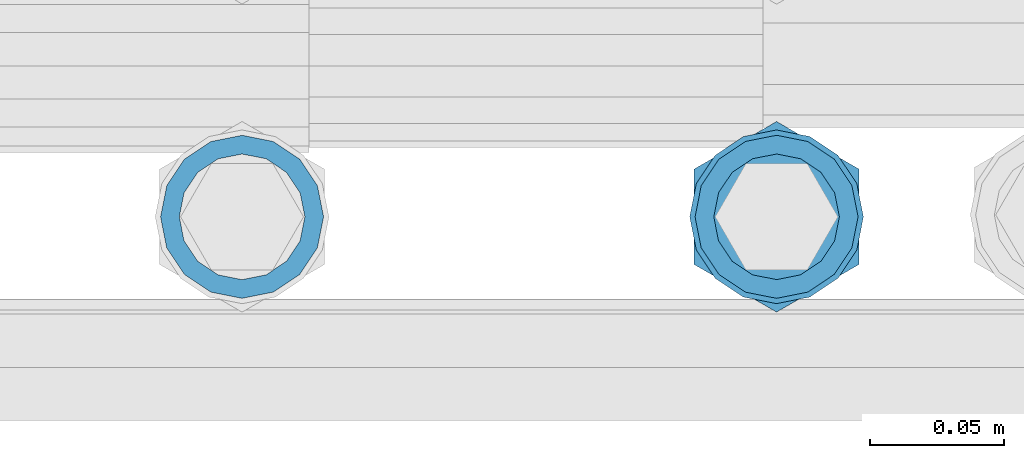
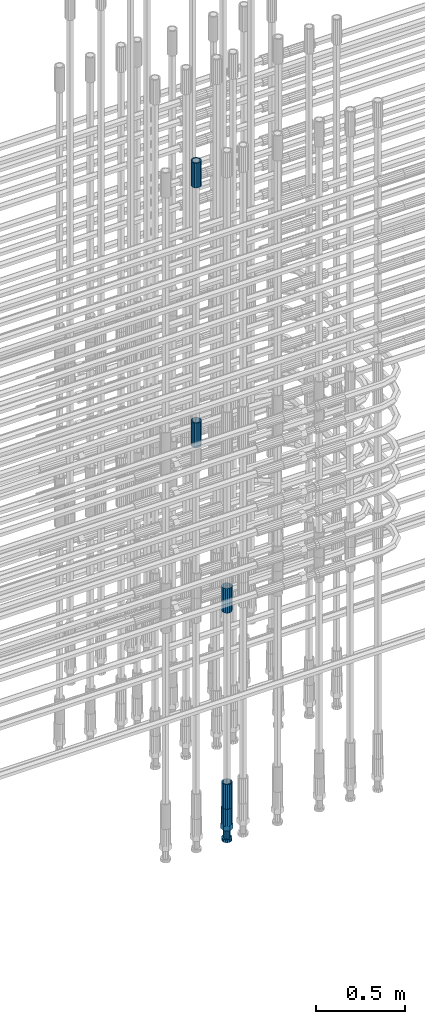
# One storey, part 22 of 119: 5 beams.
"""IFC2X3 building model written with IfcOpenShell, lengths in millimetres."""

import ifcopenshell
import ifcopenshell.guid

model = None  # the IFC model being written
_history = None  # IfcOwnerHistory: only IFC2X3 demands one
_inside = {}  # id of a spatial element -> (the spatial element, [elements in it])
_under = {}  # id of a project, library or spatial element -> (it, [spatial elements below it])
_declared = {}  # id of a project -> (the project, [libraries it declares])
_typed = {}  # id of a type object -> (the type object, [elements of that type])
_made_of = {}  # id of a material, layer set ... -> (it, [elements and type objects made of it])


def new_model(schema):
    """Start an empty IFC model of exactly this schema.

    Asked for "IFC4X3", IfcOpenShell would pick the latest addendum, in which some entities
    have other attributes; the version numbers below select the first issue.
    IFC2X3 requires an IfcOwnerHistory on every rooted entity: one is made here for all.
    """
    global model, _history
    if schema == "IFC4X3":
        model = ifcopenshell.file(schema_version=(4, 3, 0, 0))
    else:
        model = ifcopenshell.file(schema=schema)
    _inside.clear()
    _under.clear()
    _declared.clear()
    _typed.clear()
    _made_of.clear()
    _history = None
    if model.schema == "IFC2X3":
        org = make("IfcOrganization", Name="unknown")
        user = make(
            "IfcPersonAndOrganization",
            ThePerson=make("IfcPerson", FamilyName="unknown"),
            TheOrganization=org,
        )
        app = make(
            "IfcApplication",
            ApplicationDeveloper=org,
            Version="unknown",
            ApplicationFullName="unknown",
            ApplicationIdentifier="unknown",
        )
        _history = make(
            "IfcOwnerHistory",
            OwningUser=user,
            OwningApplication=app,
            ChangeAction="ADDED",
            CreationDate=0,
        )
    return model


def make(cls, **values):
    """One entity of the class cls with the attributes given. An attribute that is None is left unset."""
    return model.create_entity(
        cls, **{name: value for name, value in values.items() if value is not None}
    )


def rooted(cls, **values):
    """An entity with a GlobalId (a new one), such as an element, a storey or a relation."""
    return make(cls, GlobalId=ifcopenshell.guid.new(), OwnerHistory=_history, **values)


def si_unit(unit_type, name, prefix=None):
    """IfcSIUnit, for example si_unit("LENGTHUNIT", "METRE", prefix="MILLI")."""
    return make("IfcSIUnit", UnitType=unit_type, Prefix=prefix, Name=name)


def assignment(units):
    """IfcUnitAssignment: the units of a project."""
    return None if units is None else make("IfcUnitAssignment", Units=units)


def point(xyz):
    """IfcCartesianPoint."""
    return None if xyz is None else make("IfcCartesianPoint", Coordinates=xyz)


def direction(xyz):
    """IfcDirection."""
    return None if xyz is None else make("IfcDirection", DirectionRatios=xyz)


def frame(location, z_axis=None, x_axis=None):
    """IfcAxis2Placement3D, a coordinate frame: its origin and axes. An axis left out is left unset."""
    return make(
        "IfcAxis2Placement3D",
        Location=point(location),
        Axis=direction(z_axis),
        RefDirection=direction(x_axis),
    )


def origin_with_axes():
    """The frame at (0, 0, 0) with the z axis (0, 0, 1) and the x axis (1, 0, 0) written out."""
    return frame((0.0, 0.0, 0.0), z_axis=(0.0, 0.0, 1.0), x_axis=(1.0, 0.0, 0.0))


def place(relative_to, where):
    """IfcLocalPlacement: puts the frame where relative to a parent placement (None: the world)."""
    return make(
        "IfcLocalPlacement", PlacementRelTo=relative_to, RelativePlacement=where
    )


def context(
    kind, dimensions, precision=None, world=None, true_north=None, identifier=None
):
    """IfcGeometricRepresentationContext, for example the 3D "Model" context."""
    return make(
        "IfcGeometricRepresentationContext",
        ContextIdentifier=identifier,
        ContextType=kind,
        CoordinateSpaceDimension=dimensions,
        Precision=precision,
        WorldCoordinateSystem=world,
        TrueNorth=true_north,
    )


def subcontext(parent, identifier, kind, view, scale=None):
    """IfcGeometricRepresentationSubContext, for example "Body" below "Model"."""
    return make(
        "IfcGeometricRepresentationSubContext",
        ContextIdentifier=identifier,
        ContextType=kind,
        ParentContext=parent,
        TargetScale=scale,
        TargetView=view,
    )


def project(units=None, contexts=None):
    """IfcProject with its units and contexts."""
    return rooted(
        "IfcProject",
        Name="project",
        RepresentationContexts=contexts,
        UnitsInContext=assignment(units),
    )


def spatial(cls, under=None, at=None, **own):
    """A site, building, storey or space (cls), placed at a placement, below another one or the project."""
    s = rooted(cls, ObjectPlacement=at, **own)
    if under is not None:
        _under.setdefault(under.id(), (under, []))[1].append(s)
    return s


def faces_of(points, faces, orient=None, outer=None):
    """IfcFace entities. A face is a list of loops; a loop is a list of indices into points, from 0.

    orient and outer hold one flag for each loop. By default every Orientation is true, the
    first loop of a face is its IfcFaceOuterBound and the others are IfcFaceBound.
    """
    made = []
    for i, loops in enumerate(faces):
        bounds = []
        for j, loop in enumerate(loops):
            is_outer = j == 0 if outer is None else outer[i][j]
            bounds.append(
                make(
                    "IfcFaceOuterBound" if is_outer else "IfcFaceBound",
                    Bound=make("IfcPolyLoop", Polygon=[points[k] for k in loop]),
                    Orientation=True if orient is None else orient[i][j],
                )
            )
        made.append(make("IfcFace", Bounds=bounds))
    return made


def faceted_brep(points, faces, orient=None, outer=None, voids=None):
    """IfcFacetedBrep: a solid bounded by flat faces; with voids (closed shells), ...WithVoids."""
    shared = [point(p) for p in points]
    hull = make("IfcClosedShell", CfsFaces=faces_of(shared, faces, orient, outer))
    if voids is None:
        return make("IfcFacetedBrep", Outer=hull)
    return make(
        "IfcFacetedBrepWithVoids",
        Outer=hull,
        Voids=[
            make(cls, CfsFaces=faces_of(shared, fs, o, b)) for cls, fs, o, b in voids
        ],
    )


def shape(context_of_items, identifier, shape_type, items):
    """IfcShapeRepresentation: the items that make up one representation, for example the "Body"."""
    return make(
        "IfcShapeRepresentation",
        ContextOfItems=context_of_items,
        RepresentationIdentifier=identifier,
        RepresentationType=shape_type,
        Items=items,
    )


def material(Name=None, Category=None):
    """IfcMaterial."""
    return make("IfcMaterial", Name=Name, Category=Category)


def made_of(thing, what):
    """Note that an element or type object is made of a material, layer set ...; save() writes the relation."""
    if what is not None:
        _made_of.setdefault(what.id(), (what, []))[1].append(thing)
    return thing


def type_object(cls, material=None, **own):
    """A type object (cls), such as IfcWallType, which elements share."""
    return made_of(rooted(cls, **own), material)


def element(
    cls,
    number,
    at=None,
    inside=None,
    cuts=None,
    type_object=None,
    material=None,
    context=None,
    identifier="Body",
    shape_type=None,
    held_by="IfcProductDefinitionShape",
    body=None,
    shapes=None,
    **own,
):
    """One element of the class cls, such as IfcWall. Its Tag is "e" and its number.

    at: its placement. inside: the storey or other place that contains it. cuts: it is an
    opening in that element (IfcRelVoidsElement). A single representation is given by context,
    identifier, shape_type and body (its items); several are given by shapes. held_by: the class
    of the entity that holds the representations. save() writes the other relations.
    """
    e = rooted(cls, Tag="e%d" % number, ObjectPlacement=at, **own)
    if body is not None:
        shapes = [shape(context, identifier, shape_type, body)]
    if shapes is not None:
        e.Representation = make(held_by, Representations=shapes)
    if inside is not None:
        _inside.setdefault(inside.id(), (inside, []))[1].append(e)
    if cuts is not None:
        rooted(
            "IfcRelVoidsElement", RelatingBuildingElement=cuts, RelatedOpeningElement=e
        )
    if type_object is not None:
        _typed.setdefault(type_object.id(), (type_object, []))[1].append(e)
    return made_of(e, material)


def aggregate(whole, parts):
    """IfcRelAggregates: a whole, such as a stair, and the parts it consists of."""
    return rooted("IfcRelAggregates", RelatingObject=whole, RelatedObjects=parts)


def save(model, path):
    """Write the relations noted so far, then the file.

    IfcRelAggregates (storeys below a building ...), IfcRelContainedInSpatialStructure (elements
    in a storey), IfcRelDefinesByType, IfcRelAssociatesMaterial and IfcRelDeclares: one each for
    every whole, place, type object, material and project.
    """
    for whole, parts in _under.values():
        aggregate(whole, parts)
    for where, things in _inside.values():
        rooted(
            "IfcRelContainedInSpatialStructure",
            RelatedElements=things,
            RelatingStructure=where,
        )
    for kind, things in _typed.values():
        rooted("IfcRelDefinesByType", RelatedObjects=things, RelatingType=kind)
    for what, things in _made_of.values():
        rooted("IfcRelAssociatesMaterial", RelatedObjects=things, RelatingMaterial=what)
    for by, libraries in _declared.values():
        rooted("IfcRelDeclares", RelatingContext=by, RelatedDefinitions=libraries)
    model.write(path)


model = new_model("IFC2X3")

# Units and contexts
model_context = context("Model", 3, precision=1e-05, world=origin_with_axes())
body_context = subcontext(model_context, "Body", "Model", "MODEL_VIEW")
ifc_project = project(units=[si_unit("LENGTHUNIT", "METRE", prefix="MILLI"), si_unit("AREAUNIT", "SQUARE_METRE"), si_unit("VOLUMEUNIT", "CUBIC_METRE"), si_unit("MASSUNIT", "GRAM", prefix="KILO"), si_unit("TIMEUNIT", "SECOND"), si_unit("PLANEANGLEUNIT", "RADIAN"), si_unit("SOLIDANGLEUNIT", "STERADIAN"), si_unit("THERMODYNAMICTEMPERATUREUNIT", "DEGREE_CELSIUS"), si_unit("LUMINOUSINTENSITYUNIT", "LUMEN")], contexts=[model_context])

# Site, building, storey
site_placement = place(None, origin_with_axes())
site = spatial("IfcSite", under=ifc_project, at=site_placement, CompositionType="ELEMENT")
building_placement = place(site_placement, origin_with_axes())
building = spatial("IfcBuilding", under=site, at=building_placement, Name="Undefined", CompositionType="ELEMENT")
storey_placement = place(building_placement, origin_with_axes())
storey = spatial("IfcBuildingStorey", under=building, at=storey_placement, Name="Undefined", CompositionType="ELEMENT", Elevation=0.0)

# Beams
ifc_material = material(Name="STEEL/S275")
beam_type_1 = type_object("IfcBeamType", PredefinedType="NOTDEFINED")
beam_1_placement = place(storey_placement, frame((2035325.00639737, 6205153.78099914, 22659.9857291641), z_axis=(1.0, 0.0, 0.0), x_axis=(0.0, 0.0, 1.0)))
element("IfcBeam", 1, at=beam_1_placement, inside=storey, type_object=beam_type_1, material=ifc_material, Name="AG40N", context=body_context, shape_type="Brep", body=[
    faceted_brep([(1.62981450557709e-09, -23.4999999990687, 0.0), (7.45058059692383e-09, -21.7111690142192, 8.99306066057534), (170.000002125278, -21.711168999318, 8.99306066022245), (170.000002127141, -23.4999999844003, -3.66071617463604e-10), (4.65661287307739e-09, -16.6170093587134, 16.6170093578889), (170.000002122484, -16.6170093440451, 16.6170093575288), (1.86264514923096e-09, -8.99306066217832, 21.7111690140277), (170.000002118759, -8.99306064750999, 21.7111690136603), (2.3283064365387e-10, 9.31322574615479e-10, 23.5), (170.000002114102, 1.28056854009628e-08, 23.4999999996485), (-6.51925802230835e-09, 8.99306065868586, 21.7111690140241), (170.00000211224, 8.99306067335419, 21.7111690136639), (-7.45058059692383e-09, 16.6170093561523, 16.6170093578853), (170.000002109446, 16.6170093708206, 16.6170093575324), (-9.31322574615479e-09, 21.711169013055, 8.99306066057534), (170.000002108514, 21.7111690277234, 8.99306066022245), (-1.16415321826935e-09, 23.5000000009313, 0.0), (170.000002108514, 23.5000000144355, -3.66071617463604e-10), (-8.38190317153931e-09, 21.7111690151505, -8.99306066059444), (170.000002110377, 21.7111690300517, -8.9930606609546), (-5.58793544769287e-09, 16.6170093598776, -16.6170093579008), (170.000002113171, 16.6170093745459, -16.6170093582609), (-9.31322574615479e-10, 8.99306066334248, -21.7111690140396), (170.000002115965, 8.99306067801081, -21.7111690143961), (2.3283064365387e-10, 9.31322574615479e-10, -23.5), (170.00000211969, 1.7927959561348e-08, -23.5000000003843), (5.58793544769287e-09, -8.99306065752171, -21.7111690140396), (170.000002123415, -8.99306064285338, -21.7111690143961), (8.38190317153931e-09, -16.6170093549881, -16.6170093579008), (170.000002125278, -16.6170093403198, -16.6170093582646), (9.31322574615479e-09, -21.7111690121237, -8.99306066059444), (170.000002127141, -21.7111689972226, -8.9930606609546), (1.11758708953857e-08, -30.4999999990687, -9.54969436861575e-12), (1.30385160446167e-08, -28.1783257392235, -11.6718446871514), (170.000002129003, -28.1783257243223, -11.6718446875116), (170.000002129935, -30.4999999841675, -3.66071617463604e-10), (1.02445483207703e-08, -21.5667568228673, -21.5667568262129), (170.000002128072, -21.566756808199, -21.5667568265694), (7.45058059692383e-09, -11.6718446831219, -28.1783257416196), (170.000002125278, -11.6718446684536, -28.1783257419834), (3.72529029846191e-09, 3.95812094211578e-09, -30.5000000000277), (170.00000211969, 1.83936208486557e-08, -30.5000000003879), (-9.31322574615479e-10, 11.6718446905725, -28.1783257416232), (170.000002115965, 11.6718447052408, -28.1783257419797), (-6.51925802230835e-09, 21.5667568286881, -21.5667568262093), (170.000002110377, 21.5667568433564, -21.5667568265694), (-9.31322574615479e-09, 28.178325742716, -11.6718446871478), (170.000002108514, 28.1783257573843, -11.6718446875079), (-1.21071934700012e-08, 30.5, -5.91171556152403e-12), (170.000002106652, 30.5000000144355, -3.62433638656512e-10), (-1.21071934700012e-08, 28.1783257401548, 11.6718446871359), (170.00000210572, 28.1783257548232, 11.6718446867794), (-1.02445483207703e-08, 21.5667568240315, 21.5667568261974), (170.000002107583, 21.566756838467, 21.5667568258409), (-7.45058059692383e-09, 11.671844684286, 28.1783257416041), (170.000002110377, 11.6718446989544, 28.178325741244), (-2.79396772384644e-09, -2.56113708019257e-09, 30.5000000000159), (170.000002114102, 1.18743628263474e-08, 30.4999999996558), (1.86264514923096e-09, -11.6718446896411, 28.1783257416114), (170.000002118759, -11.67184467474, 28.178325741244), (7.45058059692383e-09, -21.5667568275239, 21.5667568261974), (170.000002123415, -21.5667568126228, 21.5667568258373), (1.02445483207703e-08, -28.1783257415518, 11.6718446871359), (170.000002127141, -28.1783257271163, 11.6718446867794)], [[[0, 1, 2, 3]], [[1, 4, 5, 2]], [[4, 6, 7, 5]], [[6, 8, 9, 7]], [[8, 10, 11, 9]], [[10, 12, 13, 11]], [[12, 14, 15, 13]], [[14, 16, 17, 15]], [[16, 18, 19, 17]], [[18, 20, 21, 19]], [[20, 22, 23, 21]], [[22, 24, 25, 23]], [[24, 26, 27, 25]], [[26, 28, 29, 27]], [[28, 30, 31, 29]], [[30, 0, 3, 31]], [[32, 33, 34, 35]], [[33, 36, 37, 34]], [[36, 38, 39, 37]], [[38, 40, 41, 39]], [[40, 42, 43, 41]], [[42, 44, 45, 43]], [[44, 46, 47, 45]], [[46, 48, 49, 47]], [[48, 50, 51, 49]], [[50, 52, 53, 51]], [[52, 54, 55, 53]], [[54, 56, 57, 55]], [[56, 58, 59, 57]], [[58, 60, 61, 59]], [[60, 62, 63, 61]], [[62, 32, 35, 63]], [[37, 39, 41, 43, 45, 47, 49, 51, 53, 55, 57, 59, 61, 63, 35, 34], [5, 7, 9, 11, 13, 15, 17, 19, 21, 23, 25, 27, 29, 31, 3, 2]], [[62, 60, 58, 56, 54, 52, 50, 48, 46, 44, 42, 40, 38, 36, 33, 32], [30, 28, 26, 24, 22, 20, 18, 16, 14, 12, 10, 8, 6, 4, 1, 0]]]),
])
beam_2_placement = place(storey_placement, frame((2035325.00639737, 6205153.78099914, 21044.6068583143), z_axis=(-0.99999999999998, 1.98000110685822e-07, 0.0), x_axis=(0.0, 0.0, -1.0)))
element("IfcBeam", 2, at=beam_2_placement, inside=storey, type_object=beam_type_1, material=ifc_material, Name="AG40N", context=body_context, shape_type="Brep", body=[
    faceted_brep([(1.62981450557709e-09, -23.4999999990687, 0.0), (7.45058059692383e-09, -21.7111690142192, 8.99306066057534), (170.000002125278, -21.711168999318, 8.99306066022245), (170.000002127141, -23.4999999844003, -3.66071617463604e-10), (4.65661287307739e-09, -16.6170093587134, 16.6170093578889), (170.000002122484, -16.6170093440451, 16.6170093575288), (1.86264514923096e-09, -8.99306066217832, 21.7111690140277), (170.000002118759, -8.99306064750999, 21.7111690136603), (2.3283064365387e-10, 9.31322574615479e-10, 23.5), (170.000002114102, 1.28056854009628e-08, 23.4999999996485), (-6.51925802230835e-09, 8.99306065868586, 21.7111690140241), (170.00000211224, 8.99306067335419, 21.7111690136639), (-7.45058059692383e-09, 16.6170093561523, 16.6170093578853), (170.000002109446, 16.6170093708206, 16.6170093575324), (-9.31322574615479e-09, 21.711169013055, 8.99306066057534), (170.000002108514, 21.7111690277234, 8.99306066022245), (-1.16415321826935e-09, 23.5000000009313, 0.0), (170.000002108514, 23.5000000144355, -3.66071617463604e-10), (-8.38190317153931e-09, 21.7111690151505, -8.99306066059444), (170.000002110377, 21.7111690300517, -8.9930606609546), (-5.58793544769287e-09, 16.6170093598776, -16.6170093579008), (170.000002113171, 16.6170093745459, -16.6170093582609), (-9.31322574615479e-10, 8.99306066334248, -21.7111690140396), (170.000002115965, 8.99306067801081, -21.7111690143961), (2.3283064365387e-10, 9.31322574615479e-10, -23.5), (170.00000211969, 1.7927959561348e-08, -23.5000000003843), (5.58793544769287e-09, -8.99306065752171, -21.7111690140396), (170.000002123415, -8.99306064285338, -21.7111690143961), (8.38190317153931e-09, -16.6170093549881, -16.6170093579008), (170.000002125278, -16.6170093403198, -16.6170093582646), (9.31322574615479e-09, -21.7111690121237, -8.99306066059444), (170.000002127141, -21.7111689972226, -8.9930606609546), (1.11758708953857e-08, -30.4999999990687, -9.54969436861575e-12), (1.30385160446167e-08, -28.1783257392235, -11.6718446871514), (170.000002129003, -28.1783257243223, -11.6718446875116), (170.000002129935, -30.4999999841675, -3.66071617463604e-10), (1.02445483207703e-08, -21.5667568228673, -21.5667568262129), (170.000002128072, -21.566756808199, -21.5667568265694), (7.45058059692383e-09, -11.6718446831219, -28.1783257416196), (170.000002125278, -11.6718446684536, -28.1783257419834), (3.72529029846191e-09, 3.95812094211578e-09, -30.5000000000277), (170.00000211969, 1.83936208486557e-08, -30.5000000003879), (-9.31322574615479e-10, 11.6718446905725, -28.1783257416232), (170.000002115965, 11.6718447052408, -28.1783257419797), (-6.51925802230835e-09, 21.5667568286881, -21.5667568262093), (170.000002110377, 21.5667568433564, -21.5667568265694), (-9.31322574615479e-09, 28.178325742716, -11.6718446871478), (170.000002108514, 28.1783257573843, -11.6718446875079), (-1.21071934700012e-08, 30.5, -5.91171556152403e-12), (170.000002106652, 30.5000000144355, -3.62433638656512e-10), (-1.21071934700012e-08, 28.1783257401548, 11.6718446871359), (170.00000210572, 28.1783257548232, 11.6718446867794), (-1.02445483207703e-08, 21.5667568240315, 21.5667568261974), (170.000002107583, 21.566756838467, 21.5667568258409), (-7.45058059692383e-09, 11.671844684286, 28.1783257416041), (170.000002110377, 11.6718446989544, 28.178325741244), (-2.79396772384644e-09, -2.56113708019257e-09, 30.5000000000159), (170.000002114102, 1.18743628263474e-08, 30.4999999996558), (1.86264514923096e-09, -11.6718446896411, 28.1783257416114), (170.000002118759, -11.67184467474, 28.178325741244), (7.45058059692383e-09, -21.5667568275239, 21.5667568261974), (170.000002123415, -21.5667568126228, 21.5667568258373), (1.02445483207703e-08, -28.1783257415518, 11.6718446871359), (170.000002127141, -28.1783257271163, 11.6718446867794)], [[[0, 1, 2, 3]], [[1, 4, 5, 2]], [[4, 6, 7, 5]], [[6, 8, 9, 7]], [[8, 10, 11, 9]], [[10, 12, 13, 11]], [[12, 14, 15, 13]], [[14, 16, 17, 15]], [[16, 18, 19, 17]], [[18, 20, 21, 19]], [[20, 22, 23, 21]], [[22, 24, 25, 23]], [[24, 26, 27, 25]], [[26, 28, 29, 27]], [[28, 30, 31, 29]], [[30, 0, 3, 31]], [[32, 33, 34, 35]], [[33, 36, 37, 34]], [[36, 38, 39, 37]], [[38, 40, 41, 39]], [[40, 42, 43, 41]], [[42, 44, 45, 43]], [[44, 46, 47, 45]], [[46, 48, 49, 47]], [[48, 50, 51, 49]], [[50, 52, 53, 51]], [[52, 54, 55, 53]], [[54, 56, 57, 55]], [[56, 58, 59, 57]], [[58, 60, 61, 59]], [[60, 62, 63, 61]], [[62, 32, 35, 63]], [[37, 39, 41, 43, 45, 47, 49, 51, 53, 55, 57, 59, 61, 63, 35, 34], [5, 7, 9, 11, 13, 15, 17, 19, 21, 23, 25, 27, 29, 31, 3, 2]], [[62, 60, 58, 56, 54, 52, 50, 48, 46, 44, 42, 40, 38, 36, 33, 32], [30, 28, 26, 24, 22, 20, 18, 16, 14, 12, 10, 8, 6, 4, 1, 0]]]),
])
beam_3_placement = place(storey_placement, frame((2035525.00620663, 6205153.79125114, 19667.715729163), z_axis=(1.0, 0.0, 0.0), x_axis=(0.0, 0.0, 1.0)))
element("IfcBeam", 3, at=beam_3_placement, inside=storey, type_object=beam_type_1, material=ifc_material, Name="AG40N", context=body_context, shape_type="Brep", body=[
    faceted_brep([(1.62981450557709e-09, -23.4999999990687, 0.0), (7.45058059692383e-09, -21.7111690142192, 8.99306066057534), (170.000002125278, -21.711168999318, 8.99306066022245), (170.000002127141, -23.4999999844003, -3.66071617463604e-10), (4.65661287307739e-09, -16.6170093587134, 16.6170093578889), (170.000002122484, -16.6170093440451, 16.6170093575288), (1.86264514923096e-09, -8.99306066217832, 21.7111690140277), (170.000002118759, -8.99306064750999, 21.7111690136603), (2.3283064365387e-10, 9.31322574615479e-10, 23.5), (170.000002114102, 1.28056854009628e-08, 23.4999999996485), (-6.51925802230835e-09, 8.99306065868586, 21.7111690140241), (170.00000211224, 8.99306067335419, 21.7111690136639), (-7.45058059692383e-09, 16.6170093561523, 16.6170093578853), (170.000002109446, 16.6170093708206, 16.6170093575324), (-9.31322574615479e-09, 21.711169013055, 8.99306066057534), (170.000002108514, 21.7111690277234, 8.99306066022245), (-1.16415321826935e-09, 23.5000000009313, 0.0), (170.000002108514, 23.5000000144355, -3.66071617463604e-10), (-8.38190317153931e-09, 21.7111690151505, -8.99306066059444), (170.000002110377, 21.7111690300517, -8.9930606609546), (-5.58793544769287e-09, 16.6170093598776, -16.6170093579008), (170.000002113171, 16.6170093745459, -16.6170093582609), (-9.31322574615479e-10, 8.99306066334248, -21.7111690140396), (170.000002115965, 8.99306067801081, -21.7111690143961), (2.3283064365387e-10, 9.31322574615479e-10, -23.5), (170.00000211969, 1.7927959561348e-08, -23.5000000003843), (5.58793544769287e-09, -8.99306065752171, -21.7111690140396), (170.000002123415, -8.99306064285338, -21.7111690143961), (8.38190317153931e-09, -16.6170093549881, -16.6170093579008), (170.000002125278, -16.6170093403198, -16.6170093582646), (9.31322574615479e-09, -21.7111690121237, -8.99306066059444), (170.000002127141, -21.7111689972226, -8.9930606609546), (1.11758708953857e-08, -30.4999999990687, -9.54969436861575e-12), (1.30385160446167e-08, -28.1783257392235, -11.6718446871514), (170.000002129003, -28.1783257243223, -11.6718446875116), (170.000002129935, -30.4999999841675, -3.66071617463604e-10), (1.02445483207703e-08, -21.5667568228673, -21.5667568262129), (170.000002128072, -21.566756808199, -21.5667568265694), (7.45058059692383e-09, -11.6718446831219, -28.1783257416196), (170.000002125278, -11.6718446684536, -28.1783257419834), (3.72529029846191e-09, 3.95812094211578e-09, -30.5000000000277), (170.00000211969, 1.83936208486557e-08, -30.5000000003879), (-9.31322574615479e-10, 11.6718446905725, -28.1783257416232), (170.000002115965, 11.6718447052408, -28.1783257419797), (-6.51925802230835e-09, 21.5667568286881, -21.5667568262093), (170.000002110377, 21.5667568433564, -21.5667568265694), (-9.31322574615479e-09, 28.178325742716, -11.6718446871478), (170.000002108514, 28.1783257573843, -11.6718446875079), (-1.21071934700012e-08, 30.5, -5.91171556152403e-12), (170.000002106652, 30.5000000144355, -3.62433638656512e-10), (-1.21071934700012e-08, 28.1783257401548, 11.6718446871359), (170.00000210572, 28.1783257548232, 11.6718446867794), (-1.02445483207703e-08, 21.5667568240315, 21.5667568261974), (170.000002107583, 21.566756838467, 21.5667568258409), (-7.45058059692383e-09, 11.671844684286, 28.1783257416041), (170.000002110377, 11.6718446989544, 28.178325741244), (-2.79396772384644e-09, -2.56113708019257e-09, 30.5000000000159), (170.000002114102, 1.18743628263474e-08, 30.4999999996558), (1.86264514923096e-09, -11.6718446896411, 28.1783257416114), (170.000002118759, -11.67184467474, 28.178325741244), (7.45058059692383e-09, -21.5667568275239, 21.5667568261974), (170.000002123415, -21.5667568126228, 21.5667568258373), (1.02445483207703e-08, -28.1783257415518, 11.6718446871359), (170.000002127141, -28.1783257271163, 11.6718446867794)], [[[0, 1, 2, 3]], [[1, 4, 5, 2]], [[4, 6, 7, 5]], [[6, 8, 9, 7]], [[8, 10, 11, 9]], [[10, 12, 13, 11]], [[12, 14, 15, 13]], [[14, 16, 17, 15]], [[16, 18, 19, 17]], [[18, 20, 21, 19]], [[20, 22, 23, 21]], [[22, 24, 25, 23]], [[24, 26, 27, 25]], [[26, 28, 29, 27]], [[28, 30, 31, 29]], [[30, 0, 3, 31]], [[32, 33, 34, 35]], [[33, 36, 37, 34]], [[36, 38, 39, 37]], [[38, 40, 41, 39]], [[40, 42, 43, 41]], [[42, 44, 45, 43]], [[44, 46, 47, 45]], [[46, 48, 49, 47]], [[48, 50, 51, 49]], [[50, 52, 53, 51]], [[52, 54, 55, 53]], [[54, 56, 57, 55]], [[56, 58, 59, 57]], [[58, 60, 61, 59]], [[60, 62, 63, 61]], [[62, 32, 35, 63]], [[37, 39, 41, 43, 45, 47, 49, 51, 53, 55, 57, 59, 61, 63, 35, 34], [5, 7, 9, 11, 13, 15, 17, 19, 21, 23, 25, 27, 29, 31, 3, 2]], [[62, 60, 58, 56, 54, 52, 50, 48, 46, 44, 42, 40, 38, 36, 33, 32], [30, 28, 26, 24, 22, 20, 18, 16, 14, 12, 10, 8, 6, 4, 1, 0]]]),
])
beam_4_placement = place(storey_placement, frame((2035525.00620663, 6205153.79125114, 18490.9668583139), z_axis=(-0.99999999999998, 1.98000110685822e-07, 0.0), x_axis=(0.0, 0.0, -1.0)))
element("IfcBeam", 4, at=beam_4_placement, inside=storey, type_object=beam_type_1, material=ifc_material, Name="AG40N", context=body_context, shape_type="Brep", body=[
    faceted_brep([(1.62981450557709e-09, -23.4999999990687, 0.0), (7.45058059692383e-09, -21.7111690142192, 8.99306066057534), (170.000002125278, -21.711168999318, 8.99306066022245), (170.000002127141, -23.4999999844003, -3.66071617463604e-10), (4.65661287307739e-09, -16.6170093587134, 16.6170093578889), (170.000002122484, -16.6170093440451, 16.6170093575288), (1.86264514923096e-09, -8.99306066217832, 21.7111690140277), (170.000002118759, -8.99306064750999, 21.7111690136603), (2.3283064365387e-10, 9.31322574615479e-10, 23.5), (170.000002114102, 1.28056854009628e-08, 23.4999999996485), (-6.51925802230835e-09, 8.99306065868586, 21.7111690140241), (170.00000211224, 8.99306067335419, 21.7111690136639), (-7.45058059692383e-09, 16.6170093561523, 16.6170093578853), (170.000002109446, 16.6170093708206, 16.6170093575324), (-9.31322574615479e-09, 21.711169013055, 8.99306066057534), (170.000002108514, 21.7111690277234, 8.99306066022245), (-1.16415321826935e-09, 23.5000000009313, 0.0), (170.000002108514, 23.5000000144355, -3.66071617463604e-10), (-8.38190317153931e-09, 21.7111690151505, -8.99306066059444), (170.000002110377, 21.7111690300517, -8.9930606609546), (-5.58793544769287e-09, 16.6170093598776, -16.6170093579008), (170.000002113171, 16.6170093745459, -16.6170093582609), (-9.31322574615479e-10, 8.99306066334248, -21.7111690140396), (170.000002115965, 8.99306067801081, -21.7111690143961), (2.3283064365387e-10, 9.31322574615479e-10, -23.5), (170.00000211969, 1.7927959561348e-08, -23.5000000003843), (5.58793544769287e-09, -8.99306065752171, -21.7111690140396), (170.000002123415, -8.99306064285338, -21.7111690143961), (8.38190317153931e-09, -16.6170093549881, -16.6170093579008), (170.000002125278, -16.6170093403198, -16.6170093582646), (9.31322574615479e-09, -21.7111690121237, -8.99306066059444), (170.000002127141, -21.7111689972226, -8.9930606609546), (1.11758708953857e-08, -30.4999999990687, -9.54969436861575e-12), (1.30385160446167e-08, -28.1783257392235, -11.6718446871514), (170.000002129003, -28.1783257243223, -11.6718446875116), (170.000002129935, -30.4999999841675, -3.66071617463604e-10), (1.02445483207703e-08, -21.5667568228673, -21.5667568262129), (170.000002128072, -21.566756808199, -21.5667568265694), (7.45058059692383e-09, -11.6718446831219, -28.1783257416196), (170.000002125278, -11.6718446684536, -28.1783257419834), (3.72529029846191e-09, 3.95812094211578e-09, -30.5000000000277), (170.00000211969, 1.83936208486557e-08, -30.5000000003879), (-9.31322574615479e-10, 11.6718446905725, -28.1783257416232), (170.000002115965, 11.6718447052408, -28.1783257419797), (-6.51925802230835e-09, 21.5667568286881, -21.5667568262093), (170.000002110377, 21.5667568433564, -21.5667568265694), (-9.31322574615479e-09, 28.178325742716, -11.6718446871478), (170.000002108514, 28.1783257573843, -11.6718446875079), (-1.21071934700012e-08, 30.5, -5.91171556152403e-12), (170.000002106652, 30.5000000144355, -3.62433638656512e-10), (-1.21071934700012e-08, 28.1783257401548, 11.6718446871359), (170.00000210572, 28.1783257548232, 11.6718446867794), (-1.02445483207703e-08, 21.5667568240315, 21.5667568261974), (170.000002107583, 21.566756838467, 21.5667568258409), (-7.45058059692383e-09, 11.671844684286, 28.1783257416041), (170.000002110377, 11.6718446989544, 28.178325741244), (-2.79396772384644e-09, -2.56113708019257e-09, 30.5000000000159), (170.000002114102, 1.18743628263474e-08, 30.4999999996558), (1.86264514923096e-09, -11.6718446896411, 28.1783257416114), (170.000002118759, -11.67184467474, 28.178325741244), (7.45058059692383e-09, -21.5667568275239, 21.5667568261974), (170.000002123415, -21.5667568126228, 21.5667568258373), (1.02445483207703e-08, -28.1783257415518, 11.6718446871359), (170.000002127141, -28.1783257271163, 11.6718446867794)], [[[0, 1, 2, 3]], [[1, 4, 5, 2]], [[4, 6, 7, 5]], [[6, 8, 9, 7]], [[8, 10, 11, 9]], [[10, 12, 13, 11]], [[12, 14, 15, 13]], [[14, 16, 17, 15]], [[16, 18, 19, 17]], [[18, 20, 21, 19]], [[20, 22, 23, 21]], [[22, 24, 25, 23]], [[24, 26, 27, 25]], [[26, 28, 29, 27]], [[28, 30, 31, 29]], [[30, 0, 3, 31]], [[32, 33, 34, 35]], [[33, 36, 37, 34]], [[36, 38, 39, 37]], [[38, 40, 41, 39]], [[40, 42, 43, 41]], [[42, 44, 45, 43]], [[44, 46, 47, 45]], [[46, 48, 49, 47]], [[48, 50, 51, 49]], [[50, 52, 53, 51]], [[52, 54, 55, 53]], [[54, 56, 57, 55]], [[56, 58, 59, 57]], [[58, 60, 61, 59]], [[60, 62, 63, 61]], [[62, 32, 35, 63]], [[37, 39, 41, 43, 45, 47, 49, 51, 53, 55, 57, 59, 61, 63, 35, 34], [5, 7, 9, 11, 13, 15, 17, 19, 21, 23, 25, 27, 29, 31, 3, 2]], [[62, 60, 58, 56, 54, 52, 50, 48, 46, 44, 42, 40, 38, 36, 33, 32], [30, 28, 26, 24, 22, 20, 18, 16, 14, 12, 10, 8, 6, 4, 1, 0]]]),
])
beam_type_2 = type_object("IfcBeamType", Name="ROD65", PredefinedType="NOTDEFINED")
beam_5_placement = place(storey_placement, frame((2035525.00620663, 6205153.79125114, 18320.9668583139), z_axis=(-0.99999999999998, 1.98000110685822e-07, 0.0), x_axis=(0.0, 0.0, -1.0)))
element("IfcBeam", 5, at=beam_5_placement, inside=storey, type_object=beam_type_2, material=ifc_material, Name="AGB40", ObjectType="ROD65", context=body_context, shape_type="Brep", body=[
    faceted_brep([(116.999999999069, 17.8249999252148, 30.8738056446964), (116.999999998137, 22.0056957420893, 23.632628078838), (116.999999999069, 12.4372115600854, 30.0260848066173), (116.999999999069, 8.17543111252598, 30.8738056446964), (117.000000000931, -17.8250000746921, 30.8738056446964), (150.200000001118, -17.8250000723638, 30.8738056446964), (150.199999999255, 17.8249999275431, 30.8738056446964), (117.000000000931, -8.17543109622784, 30.8738056446964), (117.000000001863, -22.0056959956419, 23.6326278985034), (117.000000000931, -12.4372115437873, 30.0260848066173), (117.000000001863, -35.6500000746455, -2.18278728425503e-10), (150.200000002049, -35.6500000723172, -2.18278728425503e-10), (117.000000001863, -30.8443149488885, 8.32369080289209), (117.000000001863, -30.8443149488885, -8.32369080355784), (117.000000002794, -32.4999999918509, 0.0), (117.000000000931, -17.8250000746921, -30.873805645133), (150.200000001118, -17.8250000723638, -30.873805645133), (117.000000001863, -22.0056959961075, -23.6326278982269), (117.000000000931, -8.17543109389953, -30.873805645133), (117.000000000931, -12.4372115437873, -30.0260848066173), (116.999999999069, 17.8249999252148, -30.873805645133), (150.199999999255, 17.8249999275431, -30.873805645133), (116.999999999069, 8.17543111019768, -30.873805645133), (116.999999999069, 12.4372115600854, -30.0260848066173), (116.999999998137, 22.005695742555, -23.6326280785652), (116.999999998137, 35.6499999251682, -2.18278728425503e-10), (150.199999998324, 35.6499999277294, -2.18278728425503e-10), (116.999999998137, 30.8443150522653, -8.32369036550881), (116.999999997206, 32.5000000081491, 0.0), (116.999999998137, 30.8443150522653, 8.32369036483942), (1.86264514923096e-09, -22.9809703885112, 22.9809703885621), (1.86264514923096e-09, -30.0260848065373, 12.4372115518672), (117.000000001863, -30.0260847983882, 12.4372115518672), (117.000000001863, -22.9809703803621, 22.9809703885621), (-1.86264514923096e-09, 22.9809703885112, -22.9809703885621), (-1.86264514923096e-09, 30.0260848065373, -12.4372115518672), (116.999999998137, 30.0260848146863, -12.4372115518672), (116.999999998137, 22.9809703966603, -22.9809703885621), (1.86264514923096e-09, -30.0260848065373, -12.4372115518672), (1.86264514923096e-09, -22.9809703885112, -22.9809703885621), (117.000000001863, -22.9809703803621, -22.9809703885621), (117.000000001863, -30.0260847983882, -12.4372115518672), (9.31322574615479e-10, -12.4372115519363, 30.0260848066173), (0.0, 0.0, 32.5), (-9.31322574615479e-10, 12.4372115519363, 30.0260848066173), (-1.86264514923096e-09, 22.9809703885112, 22.9809703885621), (-1.86264514923096e-09, 30.0260848065373, 12.4372115518672), (-2.79396772384644e-09, 32.5, 0.0), (-9.31322574615479e-10, 12.4372115519363, -30.0260848066173), (0.0, 0.0, -32.5), (9.31322574615479e-10, -12.4372115519363, -30.0260848066173), (2.79396772384644e-09, -32.5, 0.0), (116.999999998137, 22.9809703966603, 22.9809703885621), (116.999999998137, 30.0260848146863, 12.4372115518672), (117.0, 8.14907252788544e-09, -32.5), (117.0, 8.14907252788544e-09, 32.5), (150.200000000186, -10.5000000959262, 18.1865334791873), (150.199999999255, -9.59262251853943e-08, 20.9999999997126), (150.199999998324, 10.4999999040738, 18.1865334791873), (150.199999997392, 18.1865333835594, 10.4999999997126), (150.199999997392, 20.9999999040738, -2.87400325760245e-10), (150.199999997392, 18.1865333835594, -10.5000000002874), (150.199999998324, 10.4999999040738, -18.1865334797621), (150.199999999255, -9.59262251853943e-08, -21.0000000002874), (150.200000000186, -10.5000000959262, -18.1865334797621), (150.200000000186, -18.1865335754119, -10.5000000002874), (150.200000001118, -21.0000000959262, -2.87400325760245e-10), (150.200000000186, -18.1865335754119, 10.4999999997126), (210.979999999516, 10.4999999082647, 18.1865334791873), (210.979999999516, -9.17352735996246e-08, 20.9999999997126), (210.979999997653, 18.1865333877504, 10.4999999997126), (210.979999997653, 20.9999999082647, -2.87400325760245e-10), (210.979999997653, 18.1865333877504, -10.5000000002874), (210.979999999516, 10.4999999082647, -18.1865334797621), (210.979999999516, -9.17352735996246e-08, -21.0000000002874), (210.979999999516, -10.5000000917353, -18.1865334797621), (210.980000000447, -18.1865335712209, -10.5000000002874), (210.980000001378, -21.0000000917353, -2.87400325760245e-10), (210.980000000447, -18.1865335712209, 10.4999999997126), (210.979999999516, -10.5000000917353, 18.1865334791873), (211.001368402503, -27.7269939335529, -11.4911163272045), (211.003082515672, -21.2238095656503, -21.2238154190527), (231.002518340945, -21.2131946226582, -21.2132004554769), (231.000804228708, -27.7163789905608, -11.4805013636287), (211.001368415542, -11.4911086384673, -27.7269970399575), (231.000804241747, -11.4804936954752, -27.7163820763781), (210.996487061493, -0.0106066407170147, -30.0106107396168), (230.995922887698, 8.30227509140968e-06, -29.999995776041), (210.98918159306, 11.4698940692469, -27.7269970332745), (230.988617419265, 11.4805090120062, -27.7163820696951), (210.980564201251, 21.2025913291145, -21.2238154067054), (230.980000027455, 21.2132062721066, -21.2132004431296), (210.971946807578, 27.7057702087332, -11.4911163110701), (230.971382633783, 27.7163851517253, -11.4805013474943), (210.964641331695, 29.9893806746695, -0.0106149565435771), (230.9640771579, 29.9999956176616, 7.03221303410828e-09), (210.959759964608, 27.7057637346443, 11.4698863966551), (230.959195790812, 27.7163786776364, 11.4805013602345), (210.958045851439, 21.2025793667417, 21.2025854885032), (230.957481677644, 21.2131943097338, 21.2132004520827), (210.959759951569, 11.4698784395587, 27.705767109408), (230.959195776843, 11.4804933823179, 27.7163820729838), (210.964641305618, -0.0106235581915826, 29.9893808090674), (230.964077131823, -8.61519947648048e-06, 29.9999957726432), (210.971946774051, -11.4911242681555, 27.7057671027251), (230.971382599324, -11.4805093251634, 27.7163820663009), (210.98056416586, -21.2238215280231, 21.2025854761559), (230.979999991134, -21.2132065852638, 21.2132004397354), (210.989181559533, -27.7270004076418, 11.4698863805206), (230.988617384806, -27.7163854646496, 11.4805013441), (210.996487035416, -30.0106108735781, -0.0106149740058754), (230.995922861621, -29.999995930586, -1.04300852399319e-08)], [[[0, 1, 2, 3]], [[4, 5, 6, 0, 3, 7]], [[8, 4, 7, 9]], [[10, 11, 5, 4, 8, 12]], [[13, 10, 12, 14]], [[15, 16, 11, 10, 13, 17]], [[18, 15, 17, 19]], [[20, 21, 16, 15, 18, 22]], [[20, 22, 23, 24]], [[25, 26, 21, 20, 24, 27]], [[25, 27, 28, 29]], [[30, 31, 32, 33]], [[34, 35, 36, 37]], [[38, 39, 40, 41]], [[31, 30, 42, 43, 44, 45, 46, 47, 35, 34, 48, 49, 50, 39, 38, 51]], [[46, 45, 52, 53]], [[28, 47, 46, 53, 29]], [[27, 36, 35, 47, 28]], [[24, 37, 36, 27]], [[23, 48, 34, 37, 24]], [[22, 54, 49, 48, 23]], [[18, 54, 22]], [[19, 50, 49, 54, 18]], [[17, 40, 39, 50, 19]], [[13, 41, 40, 17]], [[14, 51, 38, 41, 13]], [[12, 32, 31, 51, 14]], [[8, 33, 32, 12]], [[9, 42, 30, 33, 8]], [[7, 55, 43, 42, 9]], [[3, 55, 7]], [[2, 44, 43, 55, 3]], [[1, 52, 45, 44, 2]], [[29, 53, 52, 1]], [[0, 6, 26, 25, 29, 1]], [[5, 11, 16, 21, 26, 6], [56, 57, 58, 59, 60, 61, 62, 63, 64, 65, 66, 67]], [[68, 58, 57, 69]], [[70, 59, 58, 68]], [[71, 60, 59, 70]], [[72, 61, 60, 71]], [[73, 62, 61, 72]], [[74, 63, 62, 73]], [[75, 64, 63, 74]], [[76, 65, 64, 75]], [[77, 66, 65, 76]], [[78, 67, 66, 77]], [[79, 56, 67, 78]], [[69, 57, 56, 79]], [[80, 81, 82, 83]], [[81, 84, 85, 82]], [[84, 86, 87, 85]], [[86, 88, 89, 87]], [[88, 90, 91, 89]], [[90, 92, 93, 91]], [[92, 94, 95, 93]], [[94, 96, 97, 95]], [[96, 98, 99, 97]], [[98, 100, 101, 99]], [[100, 102, 103, 101]], [[102, 104, 105, 103]], [[104, 106, 107, 105]], [[106, 108, 109, 107]], [[108, 110, 111, 109]], [[82, 85, 87, 89, 91, 93, 95, 97, 99, 101, 103, 105, 107, 109, 111, 83]], [[110, 80, 83, 111]], [[108, 106, 104, 102, 100, 98, 96, 94, 92, 90, 88, 86, 84, 81, 80, 110], [78, 77, 76, 75, 74, 73, 72, 71, 70, 68, 69, 79]]]),
])

save(model, "model.ifc")
